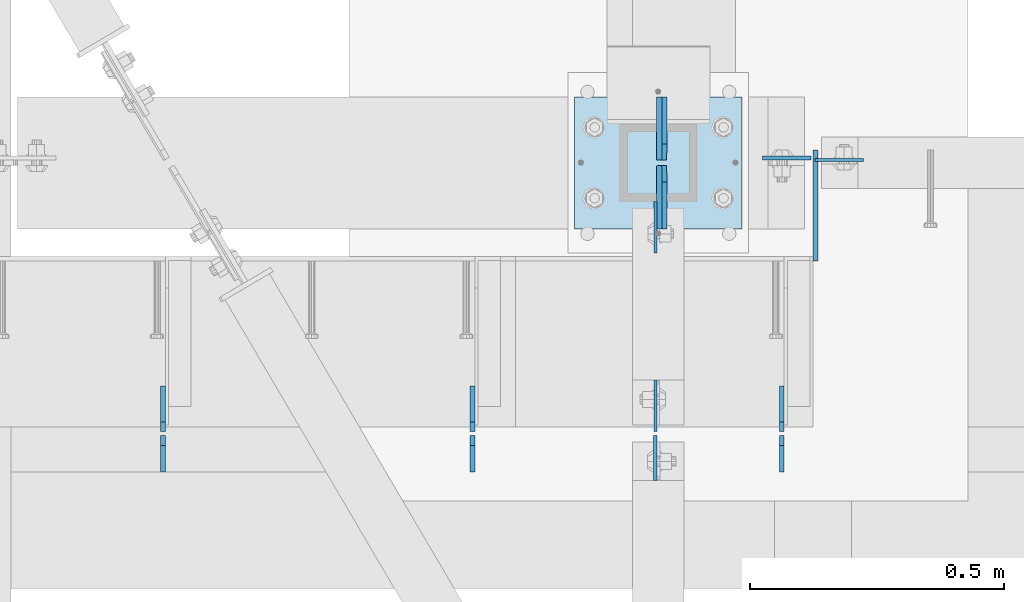
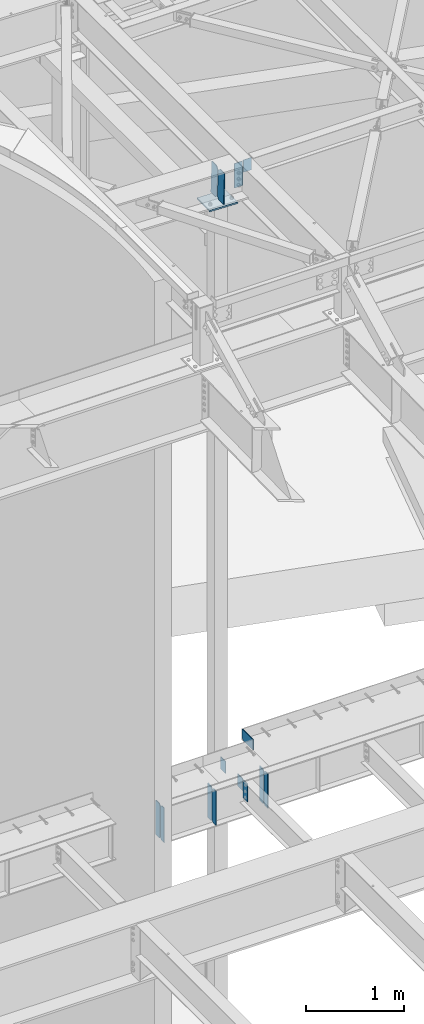
# One storey, part 1647 of 1763: 15 plates, 4 elements without a shape of their own.
"""IFC2X3 building model written with IfcOpenShell, lengths in millimetres."""

from ifc_helpers import new_model, si_unit, frame, origin_with_axes, place, context, subcontext, project, spatial, faceted_brep, material, type_object, element, aggregate, save


model = new_model("IFC2X3")

# Units and contexts
model_context = context("Model", 3, precision=1e-05, world=origin_with_axes())
body_context = subcontext(model_context, "Body", "Model", "MODEL_VIEW")
ifc_project = project(units=[si_unit("LENGTHUNIT", "METRE", prefix="MILLI"), si_unit("AREAUNIT", "SQUARE_METRE"), si_unit("VOLUMEUNIT", "CUBIC_METRE"), si_unit("MASSUNIT", "GRAM", prefix="KILO"), si_unit("TIMEUNIT", "SECOND"), si_unit("PLANEANGLEUNIT", "RADIAN"), si_unit("SOLIDANGLEUNIT", "STERADIAN"), si_unit("THERMODYNAMICTEMPERATUREUNIT", "DEGREE_CELSIUS"), si_unit("LUMINOUSINTENSITYUNIT", "LUMEN")], contexts=[model_context])

# Site, building, storey
site_placement = place(None, origin_with_axes())
site = spatial("IfcSite", under=ifc_project, at=site_placement, CompositionType="ELEMENT")
building_placement = place(site_placement, origin_with_axes())
building = spatial("IfcBuilding", under=site, at=building_placement, Name="Undefined", CompositionType="ELEMENT")
storey_placement = place(building_placement, origin_with_axes())
storey = spatial("IfcBuildingStorey", under=building, at=storey_placement, Name="Undefined", CompositionType="ELEMENT", Elevation=0.0)

# Assembly, plate
assembly_1_placement = place(storey_placement, origin_with_axes())
assembly_1 = element("IfcElementAssembly", 1, at=assembly_1_placement, inside=storey, Name="BEAM", AssemblyPlace="NOTDEFINED", PredefinedType="RIGID_FRAME")
ifc_material_1 = material(Name="STEEL/A36")
plate_type_1 = type_object("IfcPlateType", PredefinedType="NOTDEFINED")
plate_1_placement = place(assembly_1_placement, frame((-39668.3208674408, 54183.7562499993, 12420.6), z_axis=(1.0, 0.0, 0.0), x_axis=(0.0, 0.0, -1.0)))
plate_1 = element("IfcPlate", 2, at=plate_1_placement, type_object=plate_type_1, material=ifc_material_1, Name="PLATE", context=body_context, shape_type="Brep", body=[
    faceted_brep([(1.81898940354586e-12, -3.17500000000291, 0.0), (0.0, -3.17499999999927, 95.25), (0.0, 3.17499999999927, 95.25), (-1.81898940354586e-12, 3.17499999997381, 0.0), (152.399993896484, -3.17500000000291, 95.25), (152.399993896484, 3.17500000000291, 95.25), (152.399993896484, -3.17500000000291, 0.0), (152.399993896484, 3.17500000000291, 0.0)], [[[0, 1, 2, 3]], [[1, 4, 5, 2]], [[4, 6, 7, 5]], [[6, 0, 3, 7]], [[5, 7, 3, 2]], [[6, 4, 1, 0]]]),
])

# Assembly, plates
assembly_2_placement = place(storey_placement, origin_with_axes())
assembly_2 = element("IfcElementAssembly", 3, at=assembly_2_placement, inside=storey, Name="BEAM", AssemblyPlace="NOTDEFINED", PredefinedType="RIGID_FRAME")
ifc_material_2 = material(Name="STEEL/A572-50")
plate_type_2 = type_object("IfcPlateType", PredefinedType="NOTDEFINED")
plate_2_placement = place(assembly_2_placement, frame((-39667.4751514297, 53984.5250183106, 5203.82498576935), z_axis=(-0.000239024000096833, 0.99999997140427, -7.68026882087723e-06), x_axis=(3.05799998314049e-06, 7.68099997558332e-06, 0.999999999965825)))
plate_2 = element("IfcPlate", 4, at=plate_2_placement, type_object=plate_type_2, material=ifc_material_2, Name="PLATE", context=body_context, shape_type="Brep", body=[
    faceted_brep([(0.0, -4.76249999999982, 0.0), (0.00153637515631999, -4.76249999936408, 200.024982453207), (0.00153637515631999, 4.76250000061555, 200.0249824532), (0.0, 4.76249999999982, 0.0), (19.0516819331233, -4.76249999935681, 219.074838778186), (19.0516819331242, 4.76250000063737, 219.074838778171), (130.176666259691, -4.76249999960419, 219.074005127608), (130.176666259692, 4.76250000037544, 219.074005127601), (130.17500305171, -4.76250000028813, 3.63797880709171e-10), (130.175003051707, 4.7624999996915, 3.78349795937538e-10)], [[[0, 1, 2, 3]], [[1, 4, 5, 2]], [[4, 6, 7, 5]], [[6, 8, 9, 7]], [[8, 0, 3, 9]], [[5, 7, 9, 3, 2]], [[8, 6, 4, 1, 0]]]),
])
plate_type_3 = type_object("IfcPlateType", PredefinedType="NOTDEFINED")
plate_3_placement = place(assembly_2_placement, frame((-39733.9669734054, 53568.6, 4752.975), z_axis=(0.0, 0.0, 1.0), x_axis=(0.0, 1.0, 0.0)))
plate_3 = element("IfcPlate", 5, at=plate_3_placement, type_object=plate_type_3, material=ifc_material_1, Name="PLATE", context=body_context, shape_type="Brep", body=[
    faceted_brep([(0.0, -4.76249999999982, 0.0), (0.0, -4.76249999999709, 428.625), (0.0, 4.76249999999709, 428.625), (0.0, 4.76249999999982, 0.0), (53.1812477111816, -4.76249999999709, 428.625), (53.1812477111816, 4.76249999999709, 428.625), (72.2312469482422, -4.76249999999709, 409.575000762939), (72.2312469482422, 4.76249999999709, 409.575000762939), (72.2312469482422, -4.76249999999709, 19.0499992370605), (72.2312469482422, 4.76249999999709, 19.0499992370605), (53.1812477111816, -4.76249999999709, 0.0), (53.1812477111816, 4.76249999999709, 0.0)], [[[0, 1, 2, 3]], [[1, 4, 5, 2]], [[4, 6, 7, 5]], [[6, 8, 9, 7]], [[8, 10, 11, 9]], [[10, 0, 3, 11]], [[5, 7, 9, 11, 3, 2]], [[10, 8, 6, 4, 1, 0]]]),
])
plate_4_placement = place(assembly_2_placement, frame((-40343.5669734054, 53568.6, 4752.975), z_axis=(0.0, 0.0, 1.0), x_axis=(0.0, 1.0, 0.0)))
plate_4 = element("IfcPlate", 6, at=plate_4_placement, type_object=plate_type_3, material=ifc_material_1, Name="PLATE", context=body_context, shape_type="Brep", body=[
    faceted_brep([(0.0, -4.76249999999982, 0.0), (0.0, -4.76249999999709, 428.625), (0.0, 4.76249999999709, 428.625), (0.0, 4.76249999999982, 0.0), (53.1812477111816, -4.76249999999709, 428.625), (53.1812477111816, 4.76249999999709, 428.625), (72.2312469482422, -4.76249999999709, 409.575000762939), (72.2312469482422, 4.76249999999709, 409.575000762939), (72.2312469482422, -4.76249999999709, 19.0499992370605), (72.2312469482422, 4.76249999999709, 19.0499992370605), (53.1812477111816, -4.76249999999709, 0.0), (53.1812477111816, 4.76249999999709, 0.0)], [[[0, 1, 2, 3]], [[1, 4, 5, 2]], [[4, 6, 7, 5]], [[6, 8, 9, 7]], [[8, 10, 11, 9]], [[10, 0, 3, 11]], [[5, 7, 9, 11, 3, 2]], [[10, 8, 6, 4, 1, 0]]]),
])
plate_5_placement = place(assembly_2_placement, frame((-40953.1669734054, 53568.6, 4752.975), z_axis=(0.0, 0.0, 1.0), x_axis=(0.0, 1.0, 0.0)))
plate_5 = element("IfcPlate", 7, at=plate_5_placement, type_object=plate_type_3, material=ifc_material_1, Name="PLATE", context=body_context, shape_type="Brep", body=[
    faceted_brep([(0.0, -4.76249999999982, 0.0), (0.0, -4.76249999999709, 428.625), (0.0, 4.76249999999709, 428.625), (0.0, 4.76249999999982, 0.0), (53.1812477111816, -4.76249999999709, 428.625), (53.1812477111816, 4.76249999999709, 428.625), (72.2312469482422, -4.76249999999709, 409.575000762939), (72.2312469482422, 4.76249999999709, 409.575000762939), (72.2312469482422, -4.76249999999709, 19.0499992370605), (72.2312469482422, 4.76249999999709, 19.0499992370605), (53.1812477111816, -4.76249999999709, 0.0), (53.1812477111816, 4.76249999999709, 0.0)], [[[0, 1, 2, 3]], [[1, 4, 5, 2]], [[4, 6, 7, 5]], [[6, 8, 9, 7]], [[8, 10, 11, 9]], [[10, 0, 3, 11]], [[5, 7, 9, 11, 3, 2]], [[10, 8, 6, 4, 1, 0]]]),
])
plate_type_4 = type_object("IfcPlateType", PredefinedType="NOTDEFINED")
plate_6_placement = place(assembly_2_placement, frame((-39733.9669734054, 53648.76875, 4752.975), z_axis=(0.0, 0.0, 1.0), x_axis=(0.0, 1.0, 0.0)))
plate_6 = element("IfcPlate", 8, at=plate_6_placement, type_object=plate_type_4, material=ifc_material_1, Name="PLATE", context=body_context, shape_type="Brep", body=[
    faceted_brep([(6.96272763889283e-08, -4.76249999999709, 19.0499992370605), (0.0, -4.76249999999709, 409.575000762939), (0.0, 4.76249999999709, 409.575000762939), (6.96454662829638e-08, 4.76249999999709, 19.0499992370605), (19.0499992370605, -4.76249999999709, 428.625), (19.0499992370605, 4.76249999999709, 428.625), (89.6937484741211, -4.76249999999709, 428.625), (89.6937484741211, 4.76249999999709, 428.625), (89.6937484741211, -4.76249999999709, 0.0), (89.6937484741211, 4.76249999999709, 0.0), (19.0499992370533, -4.76249999996799, -2.09183781407773e-11), (19.0499992370678, 4.76250000003347, -2.09183781407773e-11)], [[[0, 1, 2, 3]], [[1, 4, 5, 2]], [[4, 6, 7, 5]], [[6, 8, 9, 7]], [[8, 10, 11, 9]], [[10, 0, 3, 11]], [[5, 7, 9, 11, 3, 2]], [[10, 8, 6, 4, 1, 0]]]),
])
plate_7_placement = place(assembly_2_placement, frame((-40343.5669734054, 53648.76875, 4752.975), z_axis=(0.0, 0.0, 1.0), x_axis=(0.0, 1.0, 0.0)))
plate_7 = element("IfcPlate", 9, at=plate_7_placement, type_object=plate_type_4, material=ifc_material_1, Name="PLATE", context=body_context, shape_type="Brep", body=[
    faceted_brep([(6.96272763889283e-08, -4.76249999999709, 19.0499992370605), (0.0, -4.76249999999709, 409.575000762939), (0.0, 4.76249999999709, 409.575000762939), (6.96454662829638e-08, 4.76249999999709, 19.0499992370605), (19.0499992370605, -4.76249999999709, 428.625), (19.0499992370605, 4.76249999999709, 428.625), (89.6937484741211, -4.76249999999709, 428.625), (89.6937484741211, 4.76249999999709, 428.625), (89.6937484741211, -4.76249999999709, 0.0), (89.6937484741211, 4.76249999999709, 0.0), (19.0499992370533, -4.76249999996799, -2.09183781407773e-11), (19.0499992370678, 4.76250000003347, -2.09183781407773e-11)], [[[0, 1, 2, 3]], [[1, 4, 5, 2]], [[4, 6, 7, 5]], [[6, 8, 9, 7]], [[8, 10, 11, 9]], [[10, 0, 3, 11]], [[5, 7, 9, 11, 3, 2]], [[10, 8, 6, 4, 1, 0]]]),
])
plate_8_placement = place(assembly_2_placement, frame((-40953.1669734054, 53648.76875, 4752.975), z_axis=(0.0, 0.0, 1.0), x_axis=(0.0, 1.0, 0.0)))
plate_8 = element("IfcPlate", 10, at=plate_8_placement, type_object=plate_type_4, material=ifc_material_1, Name="PLATE", context=body_context, shape_type="Brep", body=[
    faceted_brep([(6.96272763889283e-08, -4.76249999999709, 19.0499992370605), (0.0, -4.76249999999709, 409.575000762939), (0.0, 4.76249999999709, 409.575000762939), (6.96454662829638e-08, 4.76249999999709, 19.0499992370605), (19.0499992370605, -4.76249999999709, 428.625), (19.0499992370605, 4.76249999999709, 428.625), (89.6937484741211, -4.76249999999709, 428.625), (89.6937484741211, 4.76249999999709, 428.625), (89.6937484741211, -4.76249999999709, 0.0), (89.6937484741211, 4.76249999999709, 0.0), (19.0499992370533, -4.76249999996799, -2.09183781407773e-11), (19.0499992370678, 4.76250000003347, -2.09183781407773e-11)], [[[0, 1, 2, 3]], [[1, 4, 5, 2]], [[4, 6, 7, 5]], [[6, 8, 9, 7]], [[8, 10, 11, 9]], [[10, 0, 3, 11]], [[5, 7, 9, 11, 3, 2]], [[10, 8, 6, 4, 1, 0]]]),
])

# Assembly, plate
assembly_3_placement = place(storey_placement, origin_with_axes())
assembly_3 = element("IfcElementAssembly", 11, at=assembly_3_placement, inside=storey, Name="COLUMN", AssemblyPlace="NOTDEFINED", PredefinedType="RIGID_FRAME")
plate_type_5 = type_object("IfcPlateType", PredefinedType="NOTDEFINED")
plate_9_placement = place(assembly_3_placement, frame((-39982.6458674484, 54102.0, 5162.55), z_axis=(0.0, -1.0, 0.0), x_axis=(0.0, 0.0, -1.0)))
plate_9 = element("IfcPlate", 12, at=plate_9_placement, type_object=plate_type_5, material=ifc_material_1, Name="PLATE", context=body_context, shape_type="Brep", body=[
    faceted_brep([(1.81898940354586e-12, -3.17500000000291, 0.0), (0.0, -3.17499999999927, 101.599998474121), (0.0, 3.17499999999927, 101.599998474121), (-1.81898940354586e-12, 3.17499999997381, 0.0), (152.399993896484, -3.17499999999927, 101.599998474121), (152.399993896484, 3.17499999999927, 101.599998474121), (152.399993896484, -3.17500000000291, 0.0), (152.399993896484, 3.17500000000291, 0.0)], [[[0, 1, 2, 3]], [[1, 4, 5, 2]], [[4, 6, 7, 5]], [[6, 0, 3, 7]], [[5, 7, 3, 2]], [[6, 4, 1, 0]]]),
])

# Plate
plate_10_placement = place(assembly_2_placement, frame((-39982.6458674484, 53648.76875, 5162.55), z_axis=(0.0, 1.0, 0.0), x_axis=(0.0, 0.0, -1.0)))
plate_10 = element("IfcPlate", 13, at=plate_10_placement, type_object=plate_type_5, material=ifc_material_1, Name="PLATE", context=body_context, shape_type="Brep", body=[
    faceted_brep([(1.81898940354586e-12, -3.17500000000291, 0.0), (0.0, -3.17499999999927, 101.599998474121), (0.0, 3.17499999999927, 101.599998474121), (-1.81898940354586e-12, 3.17499999997381, 0.0), (152.399993896484, -3.17499999999927, 101.599998474121), (152.399993896484, 3.17499999999927, 101.599998474121), (152.399993896484, -3.17500000000291, 0.0), (152.399993896484, 3.17500000000291, 0.0)], [[[0, 1, 2, 3]], [[1, 4, 5, 2]], [[4, 6, 7, 5]], [[6, 0, 3, 7]], [[5, 7, 3, 2]], [[6, 4, 1, 0]]]),
])

plate_type_6 = type_object("IfcPlateType", PredefinedType="NOTDEFINED")
plate_11_placement = place(assembly_2_placement, frame((-39983.4690440317, 53640.83125, 5156.2), z_axis=(0.0, -1.0, 0.0), x_axis=(0.0, 0.0, -1.0)))
plate_11 = element("IfcPlate", 14, at=plate_11_placement, type_object=plate_type_6, material=ifc_material_1, Name="PLATE", context=body_context, shape_type="Brep", body=[
    faceted_brep([(1.81898940354586e-12, -3.17500000000291, 0.0), (0.0, -3.17499999999927, 88.9000015258789), (0.0, 3.17499999999927, 88.9000015258789), (-1.81898940354586e-12, 3.17499999997381, 0.0), (228.600006103516, -3.17499999999927, 88.9000015258789), (228.600006103516, 3.17499999999927, 88.9000015258789), (228.600006103516, -3.17500000001019, -7.27595761418343e-12), (228.600006103516, 3.17499999999563, -7.27595761418343e-12)], [[[0, 1, 2, 3]], [[1, 4, 5, 2]], [[4, 6, 7, 5]], [[6, 0, 3, 7]], [[5, 7, 3, 2]], [[6, 4, 1, 0]]]),
])

aggregate(assembly_2, [plate_2, plate_3, plate_6, plate_4, plate_7, plate_5, plate_8, plate_10, plate_11])

plate_type_7 = type_object("IfcPlateType", PredefinedType="NOTDEFINED")
plate_12_placement = place(assembly_1_placement, frame((-39676.2583674408, 54187.7252499994, 12409.7419631201), z_axis=(-1.0, 0.0, 0.0), x_axis=(0.0, 0.0, -1.0)))
plate_12 = element("IfcPlate", 15, at=plate_12_placement, type_object=plate_type_7, material=ifc_material_1, Name="PLATE", context=body_context, shape_type="Brep", body=[
    faceted_brep([(0.0, -3.96900000000096, 0.0), (0.0, -3.96900000000096, 95.25), (0.0, 3.96900000000096, 95.25), (0.0, 3.96900000000096, 0.0), (304.799987792969, -3.96899999999732, 95.25), (304.799987792969, 3.96899999999732, 95.25), (304.799987792969, -3.96900000000096, -3.63797880709171e-11), (304.799987792969, 3.96900000000096, -3.63797880709171e-11)], [[[0, 1, 2, 3]], [[1, 4, 5, 2]], [[4, 6, 7, 5]], [[6, 0, 3, 7]], [[5, 7, 3, 2]], [[6, 4, 1, 0]]]),
])

aggregate(assembly_1, [plate_12, plate_1])

# Assembly, plates
assembly_4_placement = place(storey_placement, origin_with_axes())
assembly_4 = element("IfcElementAssembly", 16, at=assembly_4_placement, inside=storey, Name="BEAM", AssemblyPlace="NOTDEFINED", PredefinedType="RIGID_FRAME")
plate_type_8 = type_object("IfcPlateType", PredefinedType="NOTDEFINED")
plate_13_placement = place(assembly_4_placement, frame((-39964.8035462866, 54048.0249999993, 12435.9287432569), z_axis=(-0.0307113389869846, 0.0, -0.999528295576282), x_axis=(0.0, 1.0, 0.0)))
plate_13 = element("IfcPlate", 17, at=plate_13_placement, type_object=plate_type_8, material=ifc_material_1, Name="PLATE", context=body_context, shape_type="Brep", body=[
    faceted_brep([(0.0, -4.76249999999982, 0.0), (0.0, -4.76249999974243, 381.000000000253), (0.0, 4.76250000028813, 381.000000000244), (0.0, 4.76249999999982, 0.0), (92.8687515258789, -4.76249999974243, 381.000000000253), (92.8687515258789, 4.76250000028813, 381.000000000244), (124.618751525879, -4.76249999976426, 349.250000000231), (124.618751525879, 4.76250000025902, 349.250000000224), (124.618751525879, -4.76249999998981, 31.7500000000218), (124.618751525879, 4.76250000003347, 31.7500000000146), (92.8687515258789, -4.76250000001164, 0.0), (92.8687515258789, 4.76250000001164, -5.45696821063757e-12)], [[[0, 1, 2, 3]], [[1, 4, 5, 2]], [[4, 6, 7, 5]], [[6, 8, 9, 7]], [[8, 10, 11, 9]], [[10, 0, 3, 11]], [[5, 7, 9, 11, 3, 2]], [[10, 8, 6, 4, 1, 0]]]),
])
plate_14_placement = place(assembly_4_placement, frame((-39964.8035462866, 54308.3749999994, 12435.9287432569), z_axis=(-0.0307113389869846, 0.0, -0.999528295576282), x_axis=(0.0, -1.0, 0.0)))
plate_14 = element("IfcPlate", 18, at=plate_14_placement, type_object=plate_type_8, material=ifc_material_1, Name="PLATE", context=body_context, shape_type="Brep", body=[
    faceted_brep([(0.0, -4.76249999999982, 0.0), (0.0, -4.76249999974243, 381.000000000253), (0.0, 4.76250000028813, 381.000000000244), (0.0, 4.76249999999982, 0.0), (92.8687515258789, -4.76249999974243, 381.000000000253), (92.8687515258789, 4.76250000028813, 381.000000000244), (124.618751525879, -4.76249999976426, 349.250000000231), (124.618751525879, 4.76250000025902, 349.250000000224), (124.618751525879, -4.76249999998981, 31.7500000000218), (124.618751525879, 4.76250000003347, 31.7500000000146), (92.8687515258789, -4.76250000001164, 0.0), (92.8687515258789, 4.76250000001164, -5.45696821063757e-12)], [[[0, 1, 2, 3]], [[1, 4, 5, 2]], [[4, 6, 7, 5]], [[6, 8, 9, 7]], [[8, 10, 11, 9]], [[10, 0, 3, 11]], [[5, 7, 9, 11, 3, 2]], [[10, 8, 6, 4, 1, 0]]]),
])
aggregate(assembly_4, [plate_13, plate_14])

# Plate
plate_type_9 = type_object("IfcPlateType", PredefinedType="NOTDEFINED")
plate_15_placement = place(assembly_3_placement, frame((-39812.360021352, 54308.375, 12021.4764995307), z_axis=(-0.999528295576282, 0.0, 0.030711338986981), x_axis=(0.0, -1.0, 0.0)))
plate_15 = element("IfcPlate", 19, at=plate_15_placement, type_object=plate_type_9, material=ifc_material_1, Name="PLATE", context=body_context, shape_type="Brep", body=[
    faceted_brep([(0.0, -9.52500000000146, 0.0), (0.0, -9.52500000025611, 330.200012207846), (0.0, 9.52499999975589, 330.200012207861), (0.0, 9.52500000000146, 0.0), (260.350006103516, -9.52500000025611, 330.200012207846), (260.350006103516, 9.52499999975589, 330.200012207861), (260.350006103516, -9.52500000000509, -7.27595761418343e-12), (260.350006103516, 9.52500000000691, 1.45519152283669e-11)], [[[0, 1, 2, 3]], [[1, 4, 5, 2]], [[4, 6, 7, 5]], [[6, 0, 3, 7]], [[5, 7, 3, 2]], [[6, 4, 1, 0]]]),
])

aggregate(assembly_3, [plate_9, plate_15])

save(model, "model.ifc")
